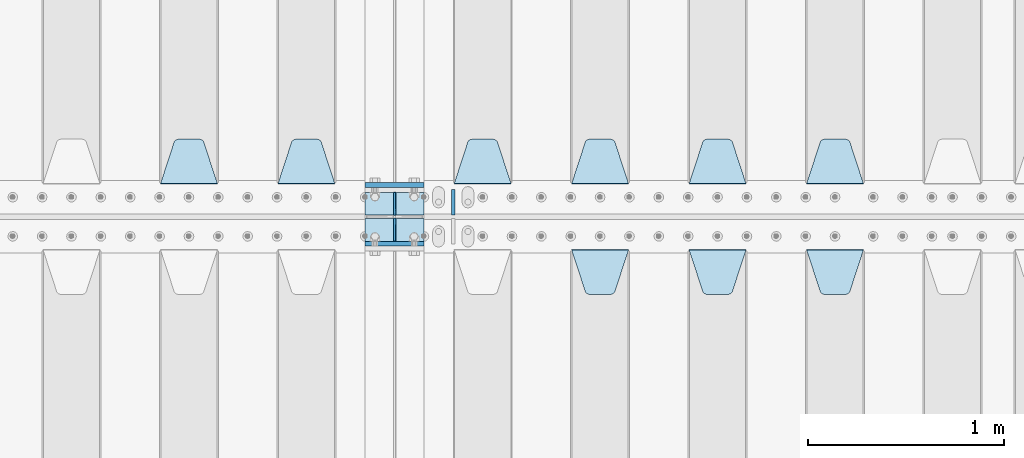
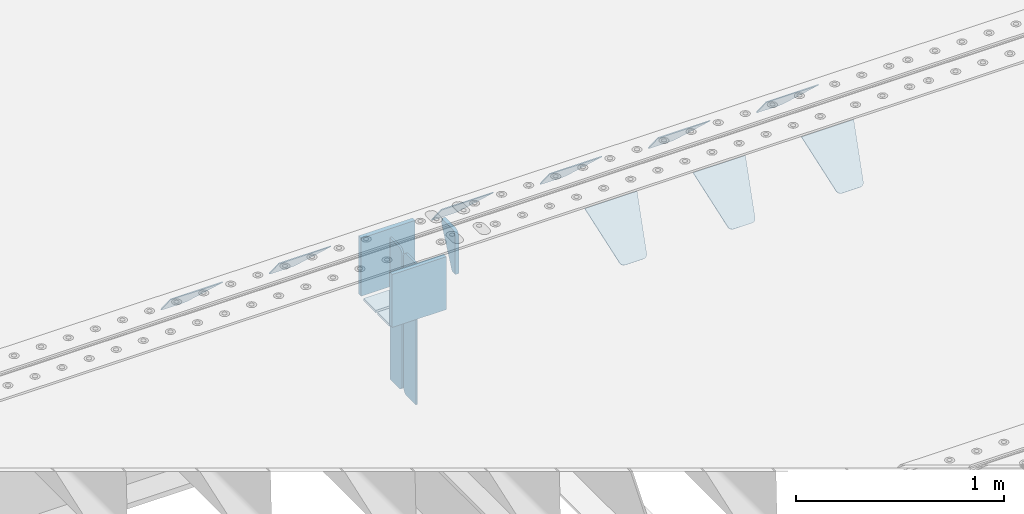
# One storey, part 216 of 257: 18 plates.
"""IFC2X3 building model written with IfcOpenShell, lengths in millimetres."""

from ifc_helpers import new_model, si_unit, frame, origin_with_axes, place, context, subcontext, project, spatial, faceted_brep, material, type_object, element, save


model = new_model("IFC2X3")

# Units and contexts
model_context = context("Model", 3, precision=1e-05, world=origin_with_axes())
body_context = subcontext(model_context, "Body", "Model", "MODEL_VIEW")
ifc_project = project(units=[si_unit("LENGTHUNIT", "METRE", prefix="MILLI"), si_unit("AREAUNIT", "SQUARE_METRE"), si_unit("VOLUMEUNIT", "CUBIC_METRE"), si_unit("MASSUNIT", "GRAM", prefix="KILO"), si_unit("TIMEUNIT", "SECOND"), si_unit("PLANEANGLEUNIT", "RADIAN"), si_unit("SOLIDANGLEUNIT", "STERADIAN"), si_unit("THERMODYNAMICTEMPERATUREUNIT", "DEGREE_CELSIUS"), si_unit("LUMINOUSINTENSITYUNIT", "LUMEN")], contexts=[model_context])

# Site, building, storey
site_placement = place(None, origin_with_axes())
site = spatial("IfcSite", under=ifc_project, at=site_placement, CompositionType="ELEMENT")
building_placement = place(site_placement, origin_with_axes())
building = spatial("IfcBuilding", under=site, at=building_placement, Name="Standard", CompositionType="ELEMENT")
storey_placement = place(building_placement, origin_with_axes())
storey = spatial("IfcBuildingStorey", under=building, at=storey_placement, Name="Undefined", CompositionType="ELEMENT", Elevation=0.0)

# Plates
ifc_material = material(Name="STEEL/S355N")
plate_type_1 = type_object("IfcPlateType", PredefinedType="NOTDEFINED")
plate_1_placement = place(storey_placement, frame((54550.0, 6162.5, -340.000000000044), z_axis=(0.0, 0.0, 1.0), x_axis=(1.0, 0.0, 0.0)))
element("IfcPlate", 1, at=plate_1_placement, inside=storey, type_object=plate_type_1, material=ifc_material, context=body_context, shape_type="Brep", body=[
    faceted_brep([(0.0, -12.5, 0.0), (0.0, -12.5, 340.0), (0.0, 12.5, 340.0), (0.0, 12.5, 0.0), (300.0, -12.5, 340.0), (300.0, 12.5, 340.0), (300.0, -12.5, 0.0), (300.0, 12.5, 0.0)], [[[0, 1, 2, 3]], [[1, 4, 5, 2]], [[4, 6, 7, 5]], [[6, 0, 3, 7]], [[5, 7, 3, 2]], [[6, 4, 1, 0]]]),
])
plate_2_placement = place(storey_placement, frame((54550.0, 5862.5, -340.0), z_axis=(0.0, 0.0, 1.0), x_axis=(1.0, 0.0, 0.0)))
element("IfcPlate", 2, at=plate_2_placement, inside=storey, type_object=plate_type_1, material=ifc_material, context=body_context, shape_type="Brep", body=[
    faceted_brep([(0.0, -12.5, 0.0), (0.0, -12.5, 310.0), (0.0, 12.5, 310.0), (0.0, 12.5, 0.0), (300.0, -12.5, 310.0), (300.0, 12.5, 310.0), (300.0, -12.5, 0.0), (300.0, 12.5, 0.0)], [[[0, 1, 2, 3]], [[1, 4, 5, 2]], [[4, 6, 7, 5]], [[6, 0, 3, 7]], [[5, 7, 3, 2]], [[6, 4, 1, 0]]]),
])
plate_type_2 = type_object("IfcPlateType", PredefinedType="NOTDEFINED")
for number, where, z_axis, x_axis in (
    (3, (54550.0, 5992.0, -343.0), (0.0, -1.0, 0.0), (1.0, 0.0, 0.0)),
    (4, (54550.0, 6008.0, -343.0), (0.0, 1.0, 0.0), (1.0, 0.0, 0.0)),
):
    element("IfcPlate", number, at=place(storey_placement, frame(where, z_axis=z_axis, x_axis=x_axis)), inside=storey, type_object=plate_type_2, material=ifc_material, context=body_context, shape_type="Brep", body=[
        faceted_brep([(0.0, -7.0, 0.0), (0.0, -7.0, 117.0), (0.0, 7.0, 117.0), (0.0, 7.0, 0.0), (300.0, -7.0, 117.0), (300.0, 7.0, 117.0), (300.0, -7.0, 0.0), (300.0, 7.0, 0.0)], [[[0, 1, 2, 3]], [[1, 4, 5, 2]], [[4, 6, 7, 5]], [[6, 0, 3, 7]], [[5, 7, 3, 2]], [[6, 4, 1, 0]]]),
    ])
plate_type_3 = type_object("IfcPlateType", PredefinedType="NOTDEFINED")
for number, where, z_axis, x_axis in (
    (5, (54700.0, 5992.0, -350.0), (0.0, 0.0, -1.0), (0.0, -1.0, 0.0)),
    (6, (54700.0, 6008.0, -350.0), (0.0, 0.0, -1.0), (0.0, 1.0, 0.0)),
):
    element("IfcPlate", number, at=place(storey_placement, frame(where, z_axis=z_axis, x_axis=x_axis)), inside=storey, type_object=plate_type_3, material=ifc_material, context=body_context, shape_type="Brep", body=[
        faceted_brep([(0.0, -5.0, 0.0), (0.0, -5.0, 480.0), (0.0, 5.0, 480.0), (0.0, 5.0, 0.0), (0.455767409633609, -5.0, 485.209445330008), (0.455767409633609, 5.0, 485.209445330008), (1.80922137642256, -5.0, 490.26060429977), (1.80922137642256, 5.0, 490.26060429977), (4.01923788646673, -5.0, 495.0), (4.01923788646673, 5.0, 495.0), (7.01866670643085, -5.0, 499.283628290596), (7.01866670643085, 5.0, 499.283628290596), (10.716371709404, -5.0, 502.981333293569), (10.716371709404, 5.0, 502.981333293569), (15.0, -5.0, 505.980762113533), (15.0, 5.0, 505.980762113533), (19.73939570023, -5.0, 508.190778623577), (19.73939570023, 5.0, 508.190778623577), (24.7905546699922, -5.0, 509.544232590366), (24.7905546699922, 5.0, 509.544232590366), (30.0, -5.0, 510.0), (30.0, 5.0, 510.0), (117.0, -5.0, 510.0), (117.0, 5.0, 510.0), (117.0, -5.0, 0.0), (117.0, 5.0, 0.0)], [[[0, 1, 2, 3]], [[1, 4, 5, 2]], [[4, 6, 7, 5]], [[6, 8, 9, 7]], [[8, 10, 11, 9]], [[10, 12, 13, 11]], [[12, 14, 15, 13]], [[14, 16, 17, 15]], [[16, 18, 19, 17]], [[18, 20, 21, 19]], [[20, 22, 23, 21]], [[22, 24, 25, 23]], [[24, 0, 3, 25]], [[5, 7, 9, 11, 13, 15, 17, 19, 21, 23, 25, 3, 2]], [[24, 22, 20, 18, 16, 14, 12, 10, 8, 6, 4, 1, 0]]]),
    ])
for number, where, z_axis, x_axis in (
    (7, (54700.0, 6008.0, -30.0), (0.0, 0.0, -1.0), (0.0, 1.0, 0.0)),
    (8, (54700.0, 5992.0, -30.0), (0.0, 0.0, -1.0), (0.0, -1.0, 0.0)),
):
    element("IfcPlate", number, at=place(storey_placement, frame(where, z_axis=z_axis, x_axis=x_axis)), inside=storey, type_object=plate_type_3, material=ifc_material, context=body_context, shape_type="Brep", body=[
        faceted_brep([(0.0, -5.0, 30.0), (0.0, -5.0, 306.0), (0.0, 5.0, 306.0), (0.0, 5.0, 30.0), (117.0, -5.0, 306.0), (117.0, 5.0, 306.0), (117.0, -5.0, 0.0), (117.0, 5.0, 0.0), (30.0, -5.0, 0.0), (30.0, 5.0, 0.0), (24.7905546699922, -5.0, 0.455767409633758), (24.7905546699922, 5.0, 0.455767409633758), (19.7393957002296, -5.0, 1.80922137642275), (19.7393957002296, 5.0, 1.80922137642275), (15.0, -5.0, 4.01923788646684), (15.0, 5.0, 4.01923788646684), (10.7163717094036, -5.0, 7.01866670643066), (10.7163717094036, 5.0, 7.01866670643066), (7.01866670643085, -5.0, 10.7163717094038), (7.01866670643085, 5.0, 10.7163717094038), (4.01923788646673, -5.0, 15.0), (4.01923788646673, 5.0, 15.0), (1.80922137642301, -5.0, 19.7393957002299), (1.80922137642301, 5.0, 19.7393957002299), (0.455767409634063, -5.0, 24.7905546699921), (0.455767409634063, 5.0, 24.7905546699921)], [[[0, 1, 2, 3]], [[1, 4, 5, 2]], [[4, 6, 7, 5]], [[6, 8, 9, 7]], [[8, 10, 11, 9]], [[10, 12, 13, 11]], [[12, 14, 15, 13]], [[14, 16, 17, 15]], [[16, 18, 19, 17]], [[18, 20, 21, 19]], [[20, 22, 23, 21]], [[22, 24, 25, 23]], [[24, 0, 3, 25]], [[5, 7, 9, 11, 13, 15, 17, 19, 21, 23, 25, 3, 2]], [[24, 22, 20, 18, 16, 14, 12, 10, 8, 6, 4, 1, 0]]]),
    ])
plate_type_4 = type_object("IfcPlateType", PredefinedType="NOTDEFINED")
plate_3_placement = place(storey_placement, frame((56805.0, 5831.76776695594, -1.767766952965), z_axis=(0.0, -0.707106781186548, -0.707106781186547), x_axis=(1.0, 0.0, 0.0)))
element("IfcPlate", 9, at=plate_3_placement, inside=storey, type_object=plate_type_4, material=ifc_material, context=body_context, shape_type="Brep", body=[
    faceted_brep([(0.0, -2.5, 0.0), (69.345504679477, -2.50000000000091, 300.17173142483), (69.345504679477, 2.5, 300.171731424831), (0.0, 2.5, 0.0), (70.927406119954, -2.50000000000091, 304.8974424154), (70.927406119954, 2.5, 304.8974424154), (73.3818627772271, -2.50000000000091, 309.234538108527), (73.3818627772271, 2.49999999999909, 309.234538108527), (76.6187032999587, -2.5, 313.023683126103), (76.6187032999587, 2.5, 313.023683126103), (80.5190132705029, -2.5, 316.125672595372), (80.5190132705029, 2.5, 316.125672595371), (84.9395038596849, -2.5, 318.426546230476), (84.9395038596849, 2.5, 318.426546230477), (89.7177759439219, -2.5, 319.841774983275), (89.7177759439219, 2.5, 319.841774983275), (94.6782862926484, -2.5, 320.319366455079), (94.6782862926484, 2.5, 320.319366455079), (195.321713707352, -2.5, 320.319366455079), (195.321713707352, 2.5, 320.319366455079), (200.282224056078, -2.5, 319.841774983275), (200.282224056078, 2.49999999999909, 319.841774983275), (205.060496140315, -2.5, 318.426546230476), (205.060496140315, 2.49999999999909, 318.426546230475), (209.480986729497, -2.5, 316.125672595371), (209.480986729497, 2.5, 316.125672595371), (213.381296700041, -2.50000000000091, 313.023683126102), (213.381296700041, 2.5, 313.023683126103), (216.618137222766, -2.50000000000091, 309.234538108527), (216.618137222766, 2.5, 309.234538108527), (219.072593880039, -2.5, 304.897442415399), (219.072593880039, 2.5, 304.897442415399), (220.654495320523, -2.50000000000091, 300.17173142483), (220.654495320523, 2.5, 300.171731424831), (290.0, -2.50000000000091, 0.0), (290.0, 2.5, 9.09494701772928e-13)], [[[0, 1, 2, 3]], [[1, 4, 5, 2]], [[4, 6, 7, 5]], [[6, 8, 9, 7]], [[8, 10, 11, 9]], [[10, 12, 13, 11]], [[12, 14, 15, 13]], [[14, 16, 17, 15]], [[16, 18, 19, 17]], [[18, 20, 21, 19]], [[20, 22, 23, 21]], [[22, 24, 25, 23]], [[24, 26, 27, 25]], [[26, 28, 29, 27]], [[28, 30, 31, 29]], [[30, 32, 33, 31]], [[32, 34, 35, 33]], [[34, 0, 3, 35]], [[5, 7, 9, 11, 13, 15, 17, 19, 21, 23, 25, 27, 29, 31, 33, 35, 3, 2]], [[34, 32, 30, 28, 26, 24, 22, 20, 18, 16, 14, 12, 10, 8, 6, 4, 1, 0]]]),
])
plate_4_placement = place(storey_placement, frame((57095.0, 6168.23223304704, -1.76776695296758), z_axis=(0.0, 0.707106781186547, -0.707106781186548), x_axis=(-1.0, 0.0, 0.0)))
element("IfcPlate", 10, at=plate_4_placement, inside=storey, type_object=plate_type_4, material=ifc_material, context=body_context, shape_type="Brep", body=[
    faceted_brep([(0.0, -2.5, 0.0), (69.345504679477, -2.50000000000091, 300.17173142483), (69.345504679477, 2.5, 300.171731424831), (0.0, 2.5, 0.0), (70.927406119954, -2.50000000000091, 304.8974424154), (70.927406119954, 2.5, 304.8974424154), (73.3818627772271, -2.50000000000091, 309.234538108527), (73.3818627772271, 2.49999999999909, 309.234538108527), (76.6187032999587, -2.5, 313.023683126103), (76.6187032999587, 2.5, 313.023683126103), (80.5190132705029, -2.5, 316.125672595372), (80.5190132705029, 2.5, 316.125672595371), (84.9395038596849, -2.5, 318.426546230476), (84.9395038596849, 2.5, 318.426546230477), (89.7177759439219, -2.5, 319.841774983275), (89.7177759439219, 2.5, 319.841774983275), (94.6782862926484, -2.5, 320.319366455079), (94.6782862926484, 2.5, 320.319366455079), (195.321713707352, -2.5, 320.319366455079), (195.321713707352, 2.5, 320.319366455079), (200.282224056078, -2.5, 319.841774983275), (200.282224056078, 2.49999999999909, 319.841774983275), (205.060496140315, -2.5, 318.426546230476), (205.060496140315, 2.49999999999909, 318.426546230475), (209.480986729497, -2.5, 316.125672595371), (209.480986729497, 2.5, 316.125672595371), (213.381296700041, -2.50000000000091, 313.023683126102), (213.381296700041, 2.5, 313.023683126103), (216.618137222766, -2.50000000000091, 309.234538108527), (216.618137222766, 2.5, 309.234538108527), (219.072593880039, -2.5, 304.897442415399), (219.072593880039, 2.5, 304.897442415399), (220.654495320523, -2.50000000000091, 300.17173142483), (220.654495320523, 2.5, 300.171731424831), (290.0, -2.50000000000091, 0.0), (290.0, 2.5, 9.09494701772928e-13)], [[[0, 1, 2, 3]], [[1, 4, 5, 2]], [[4, 6, 7, 5]], [[6, 8, 9, 7]], [[8, 10, 11, 9]], [[10, 12, 13, 11]], [[12, 14, 15, 13]], [[14, 16, 17, 15]], [[16, 18, 19, 17]], [[18, 20, 21, 19]], [[20, 22, 23, 21]], [[22, 24, 25, 23]], [[24, 26, 27, 25]], [[26, 28, 29, 27]], [[28, 30, 31, 29]], [[30, 32, 33, 31]], [[32, 34, 35, 33]], [[34, 0, 3, 35]], [[5, 7, 9, 11, 13, 15, 17, 19, 21, 23, 25, 27, 29, 31, 33, 35, 3, 2]], [[34, 32, 30, 28, 26, 24, 22, 20, 18, 16, 14, 12, 10, 8, 6, 4, 1, 0]]]),
])
plate_5_placement = place(storey_placement, frame((56495.0, 6168.23223304704, -1.76776695296758), z_axis=(0.0, 0.707106781186547, -0.707106781186548), x_axis=(-1.0, 0.0, 0.0)))
element("IfcPlate", 11, at=plate_5_placement, inside=storey, type_object=plate_type_4, material=ifc_material, context=body_context, shape_type="Brep", body=[
    faceted_brep([(0.0, -2.5, 0.0), (69.345504679477, -2.50000000000091, 300.17173142483), (69.345504679477, 2.5, 300.171731424831), (0.0, 2.5, 0.0), (70.927406119954, -2.50000000000091, 304.8974424154), (70.927406119954, 2.5, 304.8974424154), (73.3818627772271, -2.50000000000091, 309.234538108527), (73.3818627772271, 2.49999999999909, 309.234538108527), (76.6187032999587, -2.5, 313.023683126103), (76.6187032999587, 2.5, 313.023683126103), (80.5190132705029, -2.5, 316.125672595372), (80.5190132705029, 2.5, 316.125672595371), (84.9395038596849, -2.5, 318.426546230476), (84.9395038596849, 2.5, 318.426546230477), (89.7177759439219, -2.5, 319.841774983275), (89.7177759439219, 2.5, 319.841774983275), (94.6782862926484, -2.5, 320.319366455079), (94.6782862926484, 2.5, 320.319366455079), (195.321713707352, -2.5, 320.319366455079), (195.321713707352, 2.5, 320.319366455079), (200.282224056078, -2.5, 319.841774983275), (200.282224056078, 2.49999999999909, 319.841774983275), (205.060496140315, -2.5, 318.426546230476), (205.060496140315, 2.49999999999909, 318.426546230475), (209.480986729497, -2.5, 316.125672595371), (209.480986729497, 2.5, 316.125672595371), (213.381296700041, -2.50000000000091, 313.023683126102), (213.381296700041, 2.5, 313.023683126103), (216.618137222766, -2.50000000000091, 309.234538108527), (216.618137222766, 2.5, 309.234538108527), (219.072593880039, -2.5, 304.897442415399), (219.072593880039, 2.5, 304.897442415399), (220.654495320523, -2.50000000000091, 300.17173142483), (220.654495320523, 2.5, 300.171731424831), (290.0, -2.50000000000091, 0.0), (290.0, 2.5, 9.09494701772928e-13)], [[[0, 1, 2, 3]], [[1, 4, 5, 2]], [[4, 6, 7, 5]], [[6, 8, 9, 7]], [[8, 10, 11, 9]], [[10, 12, 13, 11]], [[12, 14, 15, 13]], [[14, 16, 17, 15]], [[16, 18, 19, 17]], [[18, 20, 21, 19]], [[20, 22, 23, 21]], [[22, 24, 25, 23]], [[24, 26, 27, 25]], [[26, 28, 29, 27]], [[28, 30, 31, 29]], [[30, 32, 33, 31]], [[32, 34, 35, 33]], [[34, 0, 3, 35]], [[5, 7, 9, 11, 13, 15, 17, 19, 21, 23, 25, 27, 29, 31, 33, 35, 3, 2]], [[34, 32, 30, 28, 26, 24, 22, 20, 18, 16, 14, 12, 10, 8, 6, 4, 1, 0]]]),
])
plate_6_placement = place(storey_placement, frame((55895.0, 6168.23223304704, -1.76776695296758), z_axis=(0.0, 0.707106781186547, -0.707106781186548), x_axis=(-1.0, 0.0, 0.0)))
element("IfcPlate", 12, at=plate_6_placement, inside=storey, type_object=plate_type_4, material=ifc_material, context=body_context, shape_type="Brep", body=[
    faceted_brep([(0.0, -2.5, 0.0), (69.345504679477, -2.50000000000091, 300.17173142483), (69.345504679477, 2.5, 300.171731424831), (0.0, 2.5, 0.0), (70.927406119954, -2.50000000000091, 304.8974424154), (70.927406119954, 2.5, 304.8974424154), (73.3818627772271, -2.50000000000091, 309.234538108527), (73.3818627772271, 2.49999999999909, 309.234538108527), (76.6187032999587, -2.5, 313.023683126103), (76.6187032999587, 2.5, 313.023683126103), (80.5190132705029, -2.5, 316.125672595372), (80.5190132705029, 2.5, 316.125672595371), (84.9395038596849, -2.5, 318.426546230476), (84.9395038596849, 2.5, 318.426546230477), (89.7177759439219, -2.5, 319.841774983275), (89.7177759439219, 2.5, 319.841774983275), (94.6782862926484, -2.5, 320.319366455079), (94.6782862926484, 2.5, 320.319366455079), (195.321713707352, -2.5, 320.319366455079), (195.321713707352, 2.5, 320.319366455079), (200.282224056078, -2.5, 319.841774983275), (200.282224056078, 2.49999999999909, 319.841774983275), (205.060496140315, -2.5, 318.426546230476), (205.060496140315, 2.49999999999909, 318.426546230475), (209.480986729497, -2.5, 316.125672595371), (209.480986729497, 2.5, 316.125672595371), (213.381296700041, -2.50000000000091, 313.023683126102), (213.381296700041, 2.5, 313.023683126103), (216.618137222766, -2.50000000000091, 309.234538108527), (216.618137222766, 2.5, 309.234538108527), (219.072593880039, -2.5, 304.897442415399), (219.072593880039, 2.5, 304.897442415399), (220.654495320523, -2.50000000000091, 300.17173142483), (220.654495320523, 2.5, 300.171731424831), (290.0, -2.50000000000091, 0.0), (290.0, 2.5, 9.09494701772928e-13)], [[[0, 1, 2, 3]], [[1, 4, 5, 2]], [[4, 6, 7, 5]], [[6, 8, 9, 7]], [[8, 10, 11, 9]], [[10, 12, 13, 11]], [[12, 14, 15, 13]], [[14, 16, 17, 15]], [[16, 18, 19, 17]], [[18, 20, 21, 19]], [[20, 22, 23, 21]], [[22, 24, 25, 23]], [[24, 26, 27, 25]], [[26, 28, 29, 27]], [[28, 30, 31, 29]], [[30, 32, 33, 31]], [[32, 34, 35, 33]], [[34, 0, 3, 35]], [[5, 7, 9, 11, 13, 15, 17, 19, 21, 23, 25, 27, 29, 31, 33, 35, 3, 2]], [[34, 32, 30, 28, 26, 24, 22, 20, 18, 16, 14, 12, 10, 8, 6, 4, 1, 0]]]),
])
plate_7_placement = place(storey_placement, frame((55295.0, 6168.23223304704, -1.76776695296758), z_axis=(0.0, 0.707106781186547, -0.707106781186548), x_axis=(-1.0, 0.0, 0.0)))
element("IfcPlate", 13, at=plate_7_placement, inside=storey, type_object=plate_type_4, material=ifc_material, context=body_context, shape_type="Brep", body=[
    faceted_brep([(0.0, -2.5, 0.0), (69.345504679477, -2.50000000000091, 300.17173142483), (69.345504679477, 2.5, 300.171731424831), (0.0, 2.5, 0.0), (70.927406119954, -2.50000000000091, 304.8974424154), (70.927406119954, 2.5, 304.8974424154), (73.3818627772271, -2.50000000000091, 309.234538108527), (73.3818627772271, 2.49999999999909, 309.234538108527), (76.6187032999587, -2.5, 313.023683126103), (76.6187032999587, 2.5, 313.023683126103), (80.5190132705029, -2.5, 316.125672595372), (80.5190132705029, 2.5, 316.125672595371), (84.9395038596849, -2.5, 318.426546230476), (84.9395038596849, 2.5, 318.426546230477), (89.7177759439219, -2.5, 319.841774983275), (89.7177759439219, 2.5, 319.841774983275), (94.6782862926484, -2.5, 320.319366455079), (94.6782862926484, 2.5, 320.319366455079), (195.321713707352, -2.5, 320.319366455079), (195.321713707352, 2.5, 320.319366455079), (200.282224056078, -2.5, 319.841774983275), (200.282224056078, 2.49999999999909, 319.841774983275), (205.060496140315, -2.5, 318.426546230476), (205.060496140315, 2.49999999999909, 318.426546230475), (209.480986729497, -2.5, 316.125672595371), (209.480986729497, 2.5, 316.125672595371), (213.381296700041, -2.50000000000091, 313.023683126102), (213.381296700041, 2.5, 313.023683126103), (216.618137222766, -2.50000000000091, 309.234538108527), (216.618137222766, 2.5, 309.234538108527), (219.072593880039, -2.5, 304.897442415399), (219.072593880039, 2.5, 304.897442415399), (220.654495320523, -2.50000000000091, 300.17173142483), (220.654495320523, 2.5, 300.171731424831), (290.0, -2.50000000000091, 0.0), (290.0, 2.5, 9.09494701772928e-13)], [[[0, 1, 2, 3]], [[1, 4, 5, 2]], [[4, 6, 7, 5]], [[6, 8, 9, 7]], [[8, 10, 11, 9]], [[10, 12, 13, 11]], [[12, 14, 15, 13]], [[14, 16, 17, 15]], [[16, 18, 19, 17]], [[18, 20, 21, 19]], [[20, 22, 23, 21]], [[22, 24, 25, 23]], [[24, 26, 27, 25]], [[26, 28, 29, 27]], [[28, 30, 31, 29]], [[30, 32, 33, 31]], [[32, 34, 35, 33]], [[34, 0, 3, 35]], [[5, 7, 9, 11, 13, 15, 17, 19, 21, 23, 25, 27, 29, 31, 33, 35, 3, 2]], [[34, 32, 30, 28, 26, 24, 22, 20, 18, 16, 14, 12, 10, 8, 6, 4, 1, 0]]]),
])
plate_8_placement = place(storey_placement, frame((54395.0, 6168.23223304704, -1.76776695296758), z_axis=(0.0, 0.707106781186547, -0.707106781186548), x_axis=(-1.0, 0.0, 0.0)))
element("IfcPlate", 14, at=plate_8_placement, inside=storey, type_object=plate_type_4, material=ifc_material, context=body_context, shape_type="Brep", body=[
    faceted_brep([(0.0, -2.5, 0.0), (69.345504679477, -2.50000000000091, 300.17173142483), (69.345504679477, 2.5, 300.171731424831), (0.0, 2.5, 0.0), (70.927406119954, -2.50000000000091, 304.8974424154), (70.927406119954, 2.5, 304.8974424154), (73.3818627772271, -2.50000000000091, 309.234538108527), (73.3818627772271, 2.49999999999909, 309.234538108527), (76.6187032999587, -2.5, 313.023683126103), (76.6187032999587, 2.5, 313.023683126103), (80.5190132705029, -2.5, 316.125672595372), (80.5190132705029, 2.5, 316.125672595371), (84.9395038596849, -2.5, 318.426546230476), (84.9395038596849, 2.5, 318.426546230477), (89.7177759439219, -2.5, 319.841774983275), (89.7177759439219, 2.5, 319.841774983275), (94.6782862926484, -2.5, 320.319366455079), (94.6782862926484, 2.5, 320.319366455079), (195.321713707352, -2.5, 320.319366455079), (195.321713707352, 2.5, 320.319366455079), (200.282224056078, -2.5, 319.841774983275), (200.282224056078, 2.49999999999909, 319.841774983275), (205.060496140315, -2.5, 318.426546230476), (205.060496140315, 2.49999999999909, 318.426546230475), (209.480986729497, -2.5, 316.125672595371), (209.480986729497, 2.5, 316.125672595371), (213.381296700041, -2.50000000000091, 313.023683126102), (213.381296700041, 2.5, 313.023683126103), (216.618137222766, -2.50000000000091, 309.234538108527), (216.618137222766, 2.5, 309.234538108527), (219.072593880039, -2.5, 304.897442415399), (219.072593880039, 2.5, 304.897442415399), (220.654495320523, -2.50000000000091, 300.17173142483), (220.654495320523, 2.5, 300.171731424831), (290.0, -2.50000000000091, 0.0), (290.0, 2.5, 9.09494701772928e-13)], [[[0, 1, 2, 3]], [[1, 4, 5, 2]], [[4, 6, 7, 5]], [[6, 8, 9, 7]], [[8, 10, 11, 9]], [[10, 12, 13, 11]], [[12, 14, 15, 13]], [[14, 16, 17, 15]], [[16, 18, 19, 17]], [[18, 20, 21, 19]], [[20, 22, 23, 21]], [[22, 24, 25, 23]], [[24, 26, 27, 25]], [[26, 28, 29, 27]], [[28, 30, 31, 29]], [[30, 32, 33, 31]], [[32, 34, 35, 33]], [[34, 0, 3, 35]], [[5, 7, 9, 11, 13, 15, 17, 19, 21, 23, 25, 27, 29, 31, 33, 35, 3, 2]], [[34, 32, 30, 28, 26, 24, 22, 20, 18, 16, 14, 12, 10, 8, 6, 4, 1, 0]]]),
])
plate_9_placement = place(storey_placement, frame((53795.0, 6168.23223304704, -1.76776695296758), z_axis=(0.0, 0.707106781186547, -0.707106781186548), x_axis=(-1.0, 0.0, 0.0)))
element("IfcPlate", 15, at=plate_9_placement, inside=storey, type_object=plate_type_4, material=ifc_material, context=body_context, shape_type="Brep", body=[
    faceted_brep([(0.0, -2.5, 0.0), (69.345504679477, -2.50000000000091, 300.17173142483), (69.345504679477, 2.5, 300.171731424831), (0.0, 2.5, 0.0), (70.927406119954, -2.50000000000091, 304.8974424154), (70.927406119954, 2.5, 304.8974424154), (73.3818627772271, -2.50000000000091, 309.234538108527), (73.3818627772271, 2.49999999999909, 309.234538108527), (76.6187032999587, -2.5, 313.023683126103), (76.6187032999587, 2.5, 313.023683126103), (80.5190132705029, -2.5, 316.125672595372), (80.5190132705029, 2.5, 316.125672595371), (84.9395038596849, -2.5, 318.426546230476), (84.9395038596849, 2.5, 318.426546230477), (89.7177759439219, -2.5, 319.841774983275), (89.7177759439219, 2.5, 319.841774983275), (94.6782862926484, -2.5, 320.319366455079), (94.6782862926484, 2.5, 320.319366455079), (195.321713707352, -2.5, 320.319366455079), (195.321713707352, 2.5, 320.319366455079), (200.282224056078, -2.5, 319.841774983275), (200.282224056078, 2.49999999999909, 319.841774983275), (205.060496140315, -2.5, 318.426546230476), (205.060496140315, 2.49999999999909, 318.426546230475), (209.480986729497, -2.5, 316.125672595371), (209.480986729497, 2.5, 316.125672595371), (213.381296700041, -2.50000000000091, 313.023683126102), (213.381296700041, 2.5, 313.023683126103), (216.618137222766, -2.50000000000091, 309.234538108527), (216.618137222766, 2.5, 309.234538108527), (219.072593880039, -2.5, 304.897442415399), (219.072593880039, 2.5, 304.897442415399), (220.654495320523, -2.50000000000091, 300.17173142483), (220.654495320523, 2.5, 300.171731424831), (290.0, -2.50000000000091, 0.0), (290.0, 2.5, 9.09494701772928e-13)], [[[0, 1, 2, 3]], [[1, 4, 5, 2]], [[4, 6, 7, 5]], [[6, 8, 9, 7]], [[8, 10, 11, 9]], [[10, 12, 13, 11]], [[12, 14, 15, 13]], [[14, 16, 17, 15]], [[16, 18, 19, 17]], [[18, 20, 21, 19]], [[20, 22, 23, 21]], [[22, 24, 25, 23]], [[24, 26, 27, 25]], [[26, 28, 29, 27]], [[28, 30, 31, 29]], [[30, 32, 33, 31]], [[32, 34, 35, 33]], [[34, 0, 3, 35]], [[5, 7, 9, 11, 13, 15, 17, 19, 21, 23, 25, 27, 29, 31, 33, 35, 3, 2]], [[34, 32, 30, 28, 26, 24, 22, 20, 18, 16, 14, 12, 10, 8, 6, 4, 1, 0]]]),
])
plate_10_placement = place(storey_placement, frame((56205.0, 5831.76776695594, -1.767766952965), z_axis=(0.0, -0.707106781186548, -0.707106781186547), x_axis=(1.0, 0.0, 0.0)))
element("IfcPlate", 16, at=plate_10_placement, inside=storey, type_object=plate_type_4, material=ifc_material, context=body_context, shape_type="Brep", body=[
    faceted_brep([(0.0, -2.5, 0.0), (69.345504679477, -2.50000000000091, 300.17173142483), (69.345504679477, 2.5, 300.171731424831), (0.0, 2.5, 0.0), (70.927406119954, -2.50000000000091, 304.8974424154), (70.927406119954, 2.5, 304.8974424154), (73.3818627772271, -2.50000000000091, 309.234538108527), (73.3818627772271, 2.49999999999909, 309.234538108527), (76.6187032999587, -2.5, 313.023683126103), (76.6187032999587, 2.5, 313.023683126103), (80.5190132705029, -2.5, 316.125672595372), (80.5190132705029, 2.5, 316.125672595371), (84.9395038596849, -2.5, 318.426546230476), (84.9395038596849, 2.5, 318.426546230477), (89.7177759439219, -2.5, 319.841774983275), (89.7177759439219, 2.5, 319.841774983275), (94.6782862926484, -2.5, 320.319366455079), (94.6782862926484, 2.5, 320.319366455079), (195.321713707352, -2.5, 320.319366455079), (195.321713707352, 2.5, 320.319366455079), (200.282224056078, -2.5, 319.841774983275), (200.282224056078, 2.49999999999909, 319.841774983275), (205.060496140315, -2.5, 318.426546230476), (205.060496140315, 2.49999999999909, 318.426546230475), (209.480986729497, -2.5, 316.125672595371), (209.480986729497, 2.5, 316.125672595371), (213.381296700041, -2.50000000000091, 313.023683126102), (213.381296700041, 2.5, 313.023683126103), (216.618137222766, -2.50000000000091, 309.234538108527), (216.618137222766, 2.5, 309.234538108527), (219.072593880039, -2.5, 304.897442415399), (219.072593880039, 2.5, 304.897442415399), (220.654495320523, -2.50000000000091, 300.17173142483), (220.654495320523, 2.5, 300.171731424831), (290.0, -2.50000000000091, 0.0), (290.0, 2.5, 9.09494701772928e-13)], [[[0, 1, 2, 3]], [[1, 4, 5, 2]], [[4, 6, 7, 5]], [[6, 8, 9, 7]], [[8, 10, 11, 9]], [[10, 12, 13, 11]], [[12, 14, 15, 13]], [[14, 16, 17, 15]], [[16, 18, 19, 17]], [[18, 20, 21, 19]], [[20, 22, 23, 21]], [[22, 24, 25, 23]], [[24, 26, 27, 25]], [[26, 28, 29, 27]], [[28, 30, 31, 29]], [[30, 32, 33, 31]], [[32, 34, 35, 33]], [[34, 0, 3, 35]], [[5, 7, 9, 11, 13, 15, 17, 19, 21, 23, 25, 27, 29, 31, 33, 35, 3, 2]], [[34, 32, 30, 28, 26, 24, 22, 20, 18, 16, 14, 12, 10, 8, 6, 4, 1, 0]]]),
])
plate_11_placement = place(storey_placement, frame((55605.0, 5831.76776695594, -1.767766952965), z_axis=(0.0, -0.707106781186548, -0.707106781186547), x_axis=(1.0, 0.0, 0.0)))
element("IfcPlate", 17, at=plate_11_placement, inside=storey, type_object=plate_type_4, material=ifc_material, context=body_context, shape_type="Brep", body=[
    faceted_brep([(0.0, -2.5, 0.0), (69.345504679477, -2.50000000000091, 300.17173142483), (69.345504679477, 2.5, 300.171731424831), (0.0, 2.5, 0.0), (70.927406119954, -2.50000000000091, 304.8974424154), (70.927406119954, 2.5, 304.8974424154), (73.3818627772271, -2.50000000000091, 309.234538108527), (73.3818627772271, 2.49999999999909, 309.234538108527), (76.6187032999587, -2.5, 313.023683126103), (76.6187032999587, 2.5, 313.023683126103), (80.5190132705029, -2.5, 316.125672595372), (80.5190132705029, 2.5, 316.125672595371), (84.9395038596849, -2.5, 318.426546230476), (84.9395038596849, 2.5, 318.426546230477), (89.7177759439219, -2.5, 319.841774983275), (89.7177759439219, 2.5, 319.841774983275), (94.6782862926484, -2.5, 320.319366455079), (94.6782862926484, 2.5, 320.319366455079), (195.321713707352, -2.5, 320.319366455079), (195.321713707352, 2.5, 320.319366455079), (200.282224056078, -2.5, 319.841774983275), (200.282224056078, 2.49999999999909, 319.841774983275), (205.060496140315, -2.5, 318.426546230476), (205.060496140315, 2.49999999999909, 318.426546230475), (209.480986729497, -2.5, 316.125672595371), (209.480986729497, 2.5, 316.125672595371), (213.381296700041, -2.50000000000091, 313.023683126102), (213.381296700041, 2.5, 313.023683126103), (216.618137222766, -2.50000000000091, 309.234538108527), (216.618137222766, 2.5, 309.234538108527), (219.072593880039, -2.5, 304.897442415399), (219.072593880039, 2.5, 304.897442415399), (220.654495320523, -2.50000000000091, 300.17173142483), (220.654495320523, 2.5, 300.171731424831), (290.0, -2.50000000000091, 0.0), (290.0, 2.5, 9.09494701772928e-13)], [[[0, 1, 2, 3]], [[1, 4, 5, 2]], [[4, 6, 7, 5]], [[6, 8, 9, 7]], [[8, 10, 11, 9]], [[10, 12, 13, 11]], [[12, 14, 15, 13]], [[14, 16, 17, 15]], [[16, 18, 19, 17]], [[18, 20, 21, 19]], [[20, 22, 23, 21]], [[22, 24, 25, 23]], [[24, 26, 27, 25]], [[26, 28, 29, 27]], [[28, 30, 31, 29]], [[30, 32, 33, 31]], [[32, 34, 35, 33]], [[34, 0, 3, 35]], [[5, 7, 9, 11, 13, 15, 17, 19, 21, 23, 25, 27, 29, 31, 33, 35, 3, 2]], [[34, 32, 30, 28, 26, 24, 22, 20, 18, 16, 14, 12, 10, 8, 6, 4, 1, 0]]]),
])
plate_type_5 = type_object("IfcPlateType", PredefinedType="NOTDEFINED")
plate_12_placement = place(storey_placement, frame((55000.0, 6140.0, -30.0), z_axis=(0.0, 0.0, -1.0), x_axis=(0.0, -1.0, 0.0)))
element("IfcPlate", 18, at=plate_12_placement, inside=storey, type_object=plate_type_5, material=ifc_material, context=body_context, shape_type="Brep", body=[
    faceted_brep([(0.0, -10.0, 0.0), (0.0, -10.0, 30.0), (0.0, 10.0, 30.0), (0.0, 10.0, 0.0), (102.0, -10.0, 250.0), (102.0, 10.0, 250.0), (132.0, -10.0, 250.0), (132.0, 10.0, 250.0), (132.0, -10.0, 30.0), (132.0, 10.0, 30.0), (131.544232590366, -10.0, 24.790554669992), (131.544232590366, 10.0, 24.790554669992), (130.190778623577, -10.0, 19.7393957002299), (130.190778623577, 10.0, 19.7393957002299), (127.980762113533, -10.0, 15.0), (127.980762113533, 10.0, 15.0), (124.981333293569, -10.0, 10.7163717094038), (124.981333293569, 10.0, 10.7163717094038), (121.283628290596, -10.0, 7.01866670643062), (121.283628290596, 10.0, 7.01866670643062), (117.0, -10.0, 4.01923788646684), (117.0, 10.0, 4.01923788646684), (112.26060429977, -10.0, 1.80922137642278), (112.26060429977, 10.0, 1.80922137642278), (107.209445330008, -10.0, 0.455767409633722), (107.209445330008, 10.0, 0.455767409633722), (102.0, -10.0, 0.0), (102.0, 10.0, 0.0)], [[[0, 1, 2, 3]], [[1, 4, 5, 2]], [[4, 6, 7, 5]], [[6, 8, 9, 7]], [[8, 10, 11, 9]], [[10, 12, 13, 11]], [[12, 14, 15, 13]], [[14, 16, 17, 15]], [[16, 18, 19, 17]], [[18, 20, 21, 19]], [[20, 22, 23, 21]], [[22, 24, 25, 23]], [[24, 26, 27, 25]], [[26, 0, 3, 27]], [[5, 7, 9, 11, 13, 15, 17, 19, 21, 23, 25, 27, 3, 2]], [[26, 24, 22, 20, 18, 16, 14, 12, 10, 8, 6, 4, 1, 0]]]),
])

save(model, "model.ifc")
